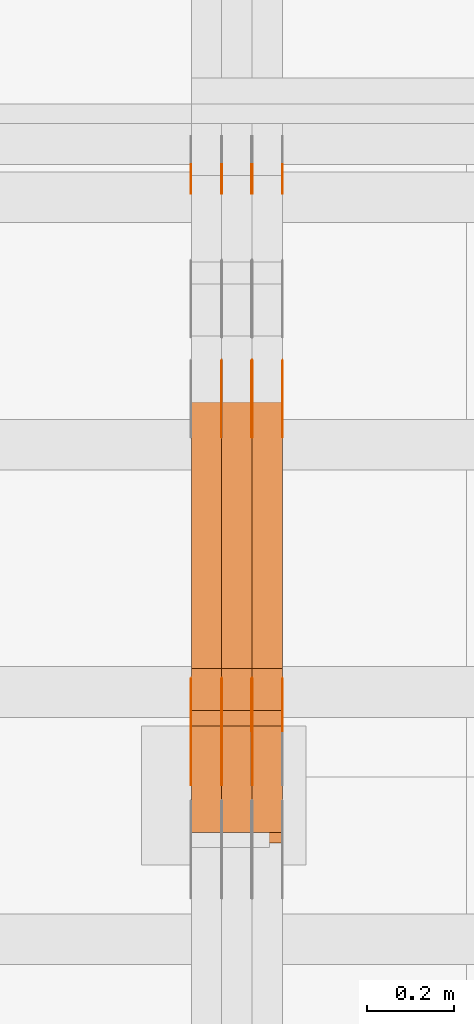
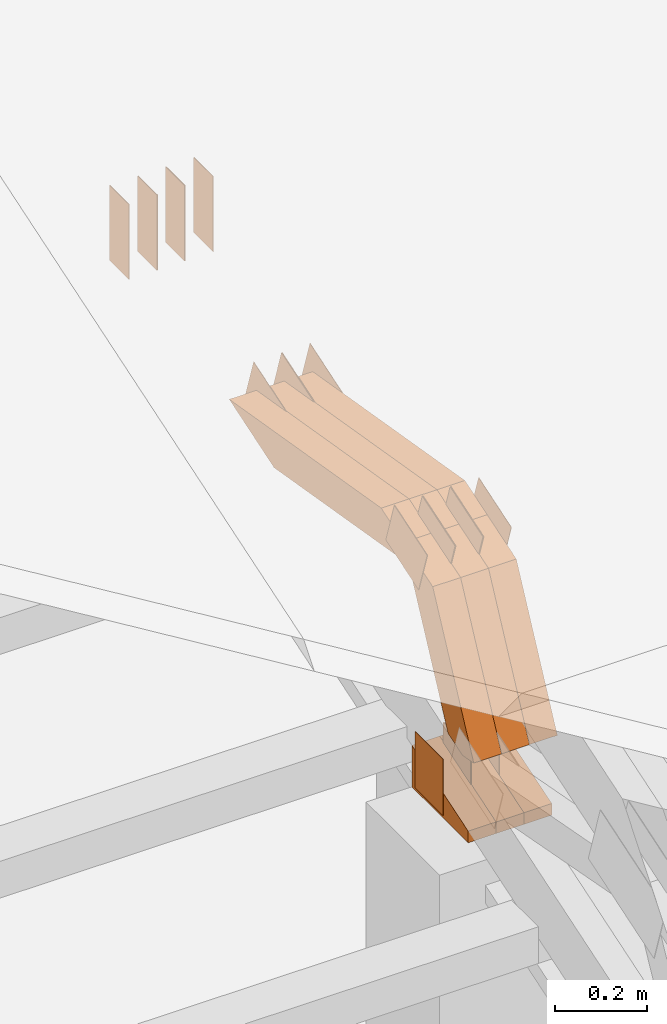
# One storey, part 80 of 385: 29 proxies.
"""IFC2X3 building model written with IfcOpenShell, lengths in millimetres."""

from ifc_helpers import new_model, entity, si_unit, converted_unit, derived_unit, direction, frame, frame_2d, origin, place, context, subcontext, project, spatial, polyline, rectangle, outline, extrude, source, transform, mapped, material, type_object, type_shapes, element, save


model = new_model("IFC2X3")

# Units and contexts
model_context = context("Model", 3, precision=0.01, world=origin(), true_north=direction((6.12303176911189e-17, 1.0)))
body_context = subcontext(model_context, "Body", "Model", "MODEL_VIEW")
ifc_project = project(units=[si_unit("LENGTHUNIT", "METRE", prefix="MILLI"), si_unit("AREAUNIT", "SQUARE_METRE"), si_unit("VOLUMEUNIT", "CUBIC_METRE"), converted_unit("PLANEANGLEUNIT", "DEGREE", entity("IfcRatioMeasure", 0.0174532925199433), si_unit("PLANEANGLEUNIT", "RADIAN"), dimensions=[0, 0, 0, 0, 0, 0, 0]), si_unit("MASSUNIT", "GRAM", prefix="KILO"), derived_unit("MASSDENSITYUNIT", [(si_unit("MASSUNIT", "GRAM", prefix="KILO"), 1), (si_unit("LENGTHUNIT", "METRE"), -3)]), si_unit("TIMEUNIT", "SECOND"), si_unit("FREQUENCYUNIT", "HERTZ"), si_unit("THERMODYNAMICTEMPERATUREUNIT", "DEGREE_CELSIUS"), derived_unit("THERMALTRANSMITTANCEUNIT", [(si_unit("MASSUNIT", "GRAM", prefix="KILO"), 1), (si_unit("THERMODYNAMICTEMPERATUREUNIT", "KELVIN"), -1), (si_unit("TIMEUNIT", "SECOND"), -3)]), derived_unit("VOLUMETRICFLOWRATEUNIT", [(si_unit("LENGTHUNIT", "METRE"), 3), (si_unit("TIMEUNIT", "SECOND"), -1)]), si_unit("ELECTRICCURRENTUNIT", "AMPERE"), si_unit("ELECTRICVOLTAGEUNIT", "VOLT"), si_unit("POWERUNIT", "WATT"), si_unit("FORCEUNIT", "NEWTON", prefix="KILO"), si_unit("ILLUMINANCEUNIT", "LUX"), si_unit("LUMINOUSFLUXUNIT", "LUMEN"), si_unit("LUMINOUSINTENSITYUNIT", "CANDELA"), derived_unit("USERDEFINED", [(si_unit("MASSUNIT", "GRAM", prefix="KILO"), -1), (si_unit("LENGTHUNIT", "METRE"), -2), (si_unit("TIMEUNIT", "SECOND"), 3), (si_unit("LUMINOUSFLUXUNIT", "LUMEN"), 1)]), derived_unit("LINEARVELOCITYUNIT", [(si_unit("LENGTHUNIT", "METRE"), 1), (si_unit("TIMEUNIT", "SECOND"), -1)]), si_unit("PRESSUREUNIT", "PASCAL"), derived_unit("USERDEFINED", [(si_unit("LENGTHUNIT", "METRE"), -2), (si_unit("MASSUNIT", "GRAM", prefix="KILO"), 1), (si_unit("TIMEUNIT", "SECOND"), -2)])], contexts=[model_context])

# Site, building, storey
site_placement = place(None, origin())
site = spatial("IfcSite", under=ifc_project, at=site_placement, CompositionType="ELEMENT")
building_placement = place(site_placement, origin())
building = spatial("IfcBuilding", under=site, at=building_placement, CompositionType="ELEMENT")
storey_placement = place(building_placement, origin())
storey = spatial("IfcBuildingStorey", under=building, at=storey_placement, Name="Default", CompositionType="ELEMENT", Elevation=0.0)

# Proxies
ifc_material_1 = material(Name="IfcSurfaceStyle #105844")
building_element_proxy_type_1 = type_object("IfcBuildingElementProxyType", PredefinedType="NOTDEFINED", material=ifc_material_1)
shared_shape_1 = source(origin(), body_context, "Body", "SweptSolid", [
    extrude(rectangle(XDim=200.0, YDim=84.0, at=frame_2d((0.0, -7.105427357601e-15), x_axis=(1.0, 0.0))), frame((100.0, 42.0, 0.0), z_axis=(0.0, 0.0, 1.0), x_axis=(-1.0, 0.0, 0.0)), (0.0, 0.0, 1.0), 1.3),
])
type_shapes(building_element_proxy_type_1, [shared_shape_1])
proxy_1_placement = place(building_placement, frame((6386.29999999999, 13702.0, 3651.4150390625), z_axis=(-1.0, 0.0, 0.0), x_axis=(0.0, 0.0, -1.0)))
element("IfcBuildingElementProxy", 1, at=proxy_1_placement, inside=storey, type_object=building_element_proxy_type_1, material=ifc_material_1, context=body_context, shape_type="MappedRepresentation", body=[
    mapped(shared_shape_1, transform((0.0, 0.0, 0.0), scale=1.0)),
])
ifc_material_2 = material(Name="IfcSurfaceStyle #105787")
building_element_proxy_type_2 = type_object("IfcBuildingElementProxyType", PredefinedType="NOTDEFINED", material=ifc_material_2)
shared_shape_2 = source(origin(), body_context, "Body", "SweptSolid", [
    extrude(rectangle(XDim=200.0, YDim=84.0, at=frame_2d((0.0, -7.105427357601e-15), x_axis=(1.0, 0.0))), frame((100.0, 42.0, 0.0), z_axis=(0.0, 0.0, 1.0), x_axis=(-1.0, 0.0, 0.0)), (0.0, 0.0, 1.0), 1.3),
])
type_shapes(building_element_proxy_type_2, [shared_shape_2])
proxy_2_placement = place(building_placement, frame((6315.0, 13702.0, 3651.4150390625), z_axis=(-1.0, 0.0, 0.0), x_axis=(0.0, 0.0, -1.0)))
element("IfcBuildingElementProxy", 2, at=proxy_2_placement, inside=storey, type_object=building_element_proxy_type_2, material=ifc_material_2, context=body_context, shape_type="MappedRepresentation", body=[
    mapped(shared_shape_2, transform((0.0, 0.0, 0.0), scale=1.0)),
])
ifc_material_3 = material(Name="IfcSurfaceStyle #105730")
building_element_proxy_type_3 = type_object("IfcBuildingElementProxyType", PredefinedType="NOTDEFINED", material=ifc_material_3)
shared_shape_3 = source(origin(), body_context, "Body", "SweptSolid", [
    extrude(rectangle(XDim=200.0, YDim=84.0, at=frame_2d((0.0, -7.105427357601e-15), x_axis=(1.0, 0.0))), frame((100.0, 42.0, 0.0), z_axis=(0.0, 0.0, 1.0), x_axis=(-1.0, 0.0, 0.0)), (0.0, 0.0, 1.0), 1.3),
])
type_shapes(building_element_proxy_type_3, [shared_shape_3])
proxy_3_placement = place(building_placement, frame((6316.29999999999, 13702.0, 3651.4150390625), z_axis=(-1.0, 0.0, 0.0), x_axis=(0.0, 0.0, -1.0)))
element("IfcBuildingElementProxy", 3, at=proxy_3_placement, inside=storey, type_object=building_element_proxy_type_3, material=ifc_material_3, context=body_context, shape_type="MappedRepresentation", body=[
    mapped(shared_shape_3, transform((0.0, 0.0, 0.0), scale=1.0)),
])
ifc_material_4 = material(Name="IfcSurfaceStyle #105673")
building_element_proxy_type_4 = type_object("IfcBuildingElementProxyType", PredefinedType="NOTDEFINED", material=ifc_material_4)
shared_shape_4 = source(origin(), body_context, "Body", "SweptSolid", [
    extrude(rectangle(XDim=200.0, YDim=84.0, at=frame_2d((0.0, -7.105427357601e-15), x_axis=(1.0, 0.0))), frame((100.0, 42.0, 0.0), z_axis=(0.0, 0.0, 1.0), x_axis=(-1.0, 0.0, 0.0)), (0.0, 0.0, 1.0), 1.29999999999998),
])
type_shapes(building_element_proxy_type_4, [shared_shape_4])
proxy_4_placement = place(building_placement, frame((6245.0, 13702.0, 3651.4150390625), z_axis=(-1.0, 0.0, 0.0), x_axis=(0.0, 0.0, -1.0)))
element("IfcBuildingElementProxy", 4, at=proxy_4_placement, inside=storey, type_object=building_element_proxy_type_4, material=ifc_material_4, context=body_context, shape_type="MappedRepresentation", body=[
    mapped(shared_shape_4, transform((0.0, 0.0, 0.0), scale=1.0)),
])
ifc_material_5 = material(Name="IfcSurfaceStyle #105616")
building_element_proxy_type_5 = type_object("IfcBuildingElementProxyType", PredefinedType="NOTDEFINED", material=ifc_material_5)
shared_shape_5 = source(origin(), body_context, "Body", "SweptSolid", [
    extrude(rectangle(XDim=200.0, YDim=84.0, at=frame_2d((0.0, -7.105427357601e-15), x_axis=(1.0, 0.0))), frame((100.0, 42.0, 0.0), z_axis=(0.0, 0.0, 1.0), x_axis=(-1.0, 0.0, 0.0)), (0.0, 0.0, 1.0), 1.29999999999998),
])
type_shapes(building_element_proxy_type_5, [shared_shape_5])
proxy_5_placement = place(building_placement, frame((6246.29999999999, 13702.0, 3651.4150390625), z_axis=(-1.0, 0.0, 0.0), x_axis=(0.0, 0.0, -1.0)))
element("IfcBuildingElementProxy", 5, at=proxy_5_placement, inside=storey, type_object=building_element_proxy_type_5, material=ifc_material_5, context=body_context, shape_type="MappedRepresentation", body=[
    mapped(shared_shape_5, transform((0.0, 0.0, 0.0), scale=1.0)),
])
ifc_material_6 = material(Name="IfcSurfaceStyle #105559")
building_element_proxy_type_6 = type_object("IfcBuildingElementProxyType", PredefinedType="NOTDEFINED", material=ifc_material_6)
shared_shape_6 = source(origin(), body_context, "Body", "SweptSolid", [
    extrude(rectangle(XDim=200.0, YDim=84.0, at=frame_2d((0.0, -7.105427357601e-15), x_axis=(1.0, 0.0))), frame((100.0, 42.0, 0.0), z_axis=(0.0, 0.0, 1.0), x_axis=(-1.0, 0.0, 0.0)), (0.0, 0.0, 1.0), 1.29999999999999),
])
type_shapes(building_element_proxy_type_6, [shared_shape_6])
proxy_6_placement = place(building_placement, frame((6175.0, 13702.0, 3651.4150390625), z_axis=(-1.0, 0.0, 0.0), x_axis=(0.0, 0.0, -1.0)))
element("IfcBuildingElementProxy", 6, at=proxy_6_placement, inside=storey, type_object=building_element_proxy_type_6, material=ifc_material_6, context=body_context, shape_type="MappedRepresentation", body=[
    mapped(shared_shape_6, transform((0.0, 0.0, 0.0), scale=1.0)),
])
ifc_material_7 = material(Name="IfcSurfaceStyle #105502")
building_element_proxy_type_7 = type_object("IfcBuildingElementProxyType", PredefinedType="NOTDEFINED", material=ifc_material_7)
shared_shape_7 = source(origin(), body_context, "Body", "SweptSolid", [
    extrude(outline(polyline([(-75.0003398116828, -59.9998507501386), (75.0003249421766, -59.9998507501386), (75.0003398116837, 59.9998507501387), (-75.0003249421775, 59.9998507501387), (-75.0003398116828, -59.9998507501386)])), frame((75.0003398116837, 60.0000773549637, 0.0), z_axis=(0.0, 0.0, 1.0), x_axis=(-1.0, 0.0, 0.0)), (0.0, 0.0, 1.0), 1.3),
])
type_shapes(building_element_proxy_type_7, [shared_shape_7])
proxy_7_placement = place(building_placement, frame((6386.29999999999, 13054.73046875, 3417.8388671875), z_axis=(-1.0, 0.0, 0.0), x_axis=(0.0, 0.951056516295124, 0.309016994375039)))
element("IfcBuildingElementProxy", 7, at=proxy_7_placement, inside=storey, type_object=building_element_proxy_type_7, material=ifc_material_7, context=body_context, shape_type="MappedRepresentation", body=[
    mapped(shared_shape_7, transform((0.0, 0.0, 0.0), scale=1.0)),
])
ifc_material_8 = material(Name="IfcSurfaceStyle #105445")
building_element_proxy_type_8 = type_object("IfcBuildingElementProxyType", PredefinedType="NOTDEFINED", material=ifc_material_8)
shared_shape_8 = source(origin(), body_context, "Body", "SweptSolid", [
    extrude(outline(polyline([(-75.0003398116828, -59.9998507501386), (75.0003249421766, -59.9998507501386), (75.0003398116837, 59.9998507501387), (-75.0003249421775, 59.9998507501387), (-75.0003398116828, -59.9998507501386)])), frame((75.0003398116837, 60.0000773549637, 0.0), z_axis=(0.0, 0.0, 1.0), x_axis=(-1.0, 0.0, 0.0)), (0.0, 0.0, 1.0), 1.3),
])
type_shapes(building_element_proxy_type_8, [shared_shape_8])
proxy_8_placement = place(building_placement, frame((6315.0, 13054.73046875, 3417.8388671875), z_axis=(-1.0, 0.0, 0.0), x_axis=(0.0, 0.951056516295124, 0.309016994375039)))
element("IfcBuildingElementProxy", 8, at=proxy_8_placement, inside=storey, type_object=building_element_proxy_type_8, material=ifc_material_8, context=body_context, shape_type="MappedRepresentation", body=[
    mapped(shared_shape_8, transform((0.0, 0.0, 0.0), scale=1.0)),
])
ifc_material_9 = material(Name="IfcSurfaceStyle #105388")
building_element_proxy_type_9 = type_object("IfcBuildingElementProxyType", PredefinedType="NOTDEFINED", material=ifc_material_9)
shared_shape_9 = source(origin(), body_context, "Body", "SweptSolid", [
    extrude(outline(polyline([(-75.0003398116828, -59.9998507501386), (75.0003249421766, -59.9998507501386), (75.0003398116837, 59.9998507501387), (-75.0003249421775, 59.9998507501387), (-75.0003398116828, -59.9998507501386)])), frame((75.0003398116837, 60.0000773549637, 0.0), z_axis=(0.0, 0.0, 1.0), x_axis=(-1.0, 0.0, 0.0)), (0.0, 0.0, 1.0), 1.3),
])
type_shapes(building_element_proxy_type_9, [shared_shape_9])
proxy_9_placement = place(building_placement, frame((6316.29999999999, 13054.73046875, 3417.8388671875), z_axis=(-1.0, 0.0, 0.0), x_axis=(0.0, 0.951056516295124, 0.309016994375039)))
element("IfcBuildingElementProxy", 9, at=proxy_9_placement, inside=storey, type_object=building_element_proxy_type_9, material=ifc_material_9, context=body_context, shape_type="MappedRepresentation", body=[
    mapped(shared_shape_9, transform((0.0, 0.0, 0.0), scale=1.0)),
])
ifc_material_10 = material(Name="IfcSurfaceStyle #105331")
building_element_proxy_type_10 = type_object("IfcBuildingElementProxyType", PredefinedType="NOTDEFINED", material=ifc_material_10)
shared_shape_10 = source(origin(), body_context, "Body", "SweptSolid", [
    extrude(outline(polyline([(-75.0003398116828, -59.9998507501386), (75.0003249421766, -59.9998507501386), (75.0003398116837, 59.9998507501387), (-75.0003249421775, 59.9998507501387), (-75.0003398116828, -59.9998507501386)])), frame((75.0003398116837, 60.0000773549637, 0.0), z_axis=(0.0, 0.0, 1.0), x_axis=(-1.0, 0.0, 0.0)), (0.0, 0.0, 1.0), 1.29999999999999),
])
type_shapes(building_element_proxy_type_10, [shared_shape_10])
proxy_10_placement = place(building_placement, frame((6245.0, 13054.73046875, 3417.8388671875), z_axis=(-1.0, 0.0, 0.0), x_axis=(0.0, 0.951056516295124, 0.309016994375039)))
element("IfcBuildingElementProxy", 10, at=proxy_10_placement, inside=storey, type_object=building_element_proxy_type_10, material=ifc_material_10, context=body_context, shape_type="MappedRepresentation", body=[
    mapped(shared_shape_10, transform((0.0, 0.0, 0.0), scale=1.0)),
])
ifc_material_11 = material(Name="IfcSurfaceStyle #103336")
building_element_proxy_type_11 = type_object("IfcBuildingElementProxyType", PredefinedType="NOTDEFINED", material=ifc_material_11)
shared_shape_11 = source(origin(), body_context, "Body", "SweptSolid", [
    extrude(rectangle(XDim=150.0, YDim=119.999999999985, at=frame_2d((-7.105427357601e-15, 0.0), x_axis=(1.0, 0.0))), frame((75.0, 60.0, 0.0), z_axis=(0.0, 0.0, 1.0), x_axis=(-1.0, 0.0, 0.0)), (0.0, 0.0, 1.0), 1.3),
])
type_shapes(building_element_proxy_type_11, [shared_shape_11])
proxy_11_placement = place(building_placement, frame((6316.29999999999, 12372.95703125, 3007.04687500001), z_axis=(-1.0, 0.0, 0.0), x_axis=(0.0, 0.0, -1.0)))
element("IfcBuildingElementProxy", 11, at=proxy_11_placement, inside=storey, type_object=building_element_proxy_type_11, material=ifc_material_11, context=body_context, shape_type="MappedRepresentation", body=[
    mapped(shared_shape_11, transform((0.0, 0.0, 0.0), scale=1.0)),
])
ifc_material_12 = material(Name="IfcSurfaceStyle #103279")
building_element_proxy_type_12 = type_object("IfcBuildingElementProxyType", PredefinedType="NOTDEFINED", material=ifc_material_12)
shared_shape_12 = source(origin(), body_context, "Body", "SweptSolid", [
    extrude(rectangle(XDim=150.0, YDim=119.999999999985, at=frame_2d((-7.105427357601e-15, 0.0), x_axis=(1.0, 0.0))), frame((75.0, 60.0, 0.0), z_axis=(0.0, 0.0, 1.0), x_axis=(-1.0, 0.0, 0.0)), (0.0, 0.0, 1.0), 1.29999999999999),
])
type_shapes(building_element_proxy_type_12, [shared_shape_12])
proxy_12_placement = place(building_placement, frame((6245.0, 12372.95703125, 3007.04687500001), z_axis=(-1.0, 0.0, 0.0), x_axis=(0.0, 0.0, -1.0)))
element("IfcBuildingElementProxy", 12, at=proxy_12_placement, inside=storey, type_object=building_element_proxy_type_12, material=ifc_material_12, context=body_context, shape_type="MappedRepresentation", body=[
    mapped(shared_shape_12, transform((0.0, 0.0, 0.0), scale=1.0)),
])
ifc_material_13 = material(Name="IfcSurfaceStyle #103222")
building_element_proxy_type_13 = type_object("IfcBuildingElementProxyType", PredefinedType="NOTDEFINED", material=ifc_material_13)
shared_shape_13 = source(origin(), body_context, "Body", "SweptSolid", [
    extrude(rectangle(XDim=150.0, YDim=119.999999999985, at=frame_2d((-7.105427357601e-15, 0.0), x_axis=(1.0, 0.0))), frame((75.0, 60.0, 0.0), z_axis=(0.0, 0.0, 1.0), x_axis=(-1.0, 0.0, 0.0)), (0.0, 0.0, 1.0), 1.29999999999999),
])
type_shapes(building_element_proxy_type_13, [shared_shape_13])
proxy_13_placement = place(building_placement, frame((6246.29999999999, 12372.95703125, 3007.04687500001), z_axis=(-1.0, 0.0, 0.0), x_axis=(0.0, 0.0, -1.0)))
element("IfcBuildingElementProxy", 13, at=proxy_13_placement, inside=storey, type_object=building_element_proxy_type_13, material=ifc_material_13, context=body_context, shape_type="MappedRepresentation", body=[
    mapped(shared_shape_13, transform((0.0, 0.0, 0.0), scale=1.0)),
])
ifc_material_14 = material(Name="IfcSurfaceStyle #103165")
building_element_proxy_type_14 = type_object("IfcBuildingElementProxyType", PredefinedType="NOTDEFINED", material=ifc_material_14)
shared_shape_14 = source(origin(), body_context, "Body", "SweptSolid", [
    extrude(rectangle(XDim=150.0, YDim=119.999999999985, at=frame_2d((-7.105427357601e-15, 0.0), x_axis=(1.0, 0.0))), frame((75.0, 60.0, 0.0), z_axis=(0.0, 0.0, 1.0), x_axis=(-1.0, 0.0, 0.0)), (0.0, 0.0, 1.0), 1.29999999999999),
])
type_shapes(building_element_proxy_type_14, [shared_shape_14])
proxy_14_placement = place(building_placement, frame((6175.0, 12372.95703125, 3007.04687500001), z_axis=(-1.0, 0.0, 0.0), x_axis=(0.0, 0.0, -1.0)))
element("IfcBuildingElementProxy", 14, at=proxy_14_placement, inside=storey, type_object=building_element_proxy_type_14, material=ifc_material_14, context=body_context, shape_type="MappedRepresentation", body=[
    mapped(shared_shape_14, transform((0.0, 0.0, 0.0), scale=1.0)),
])
ifc_material_15 = material(Name="IfcSurfaceStyle #96268")
building_element_proxy_type_15 = type_object("IfcBuildingElementProxyType", PredefinedType="NOTDEFINED", material=ifc_material_15)
shared_shape_15 = source(origin(), body_context, "Body", "SweptSolid", [
    extrude(outline(polyline([(-74.9998754286244, -60.0000016373506), (74.9998605591063, -60.0000016373506), (74.9998754286244, 60.0000016373506), (-74.9998605591063, 60.0000016373506), (-74.9998754286244, -60.0000016373506)])), frame((74.9998754286244, 60.0000016373506, 0.0), z_axis=(0.0, 0.0, 1.0), x_axis=(-1.0, 0.0, 0.0)), (0.0, 0.0, 1.0), 1.3),
])
type_shapes(building_element_proxy_type_15, [shared_shape_15])
proxy_15_placement = place(building_placement, frame((6386.29999999999, 12321.1620861463, 3506.17707344366), z_axis=(-1.0, 0.0, 0.0), x_axis=(0.0, 0.951056516295154, 0.309016994374948)))
element("IfcBuildingElementProxy", 15, at=proxy_15_placement, inside=storey, type_object=building_element_proxy_type_15, material=ifc_material_15, context=body_context, shape_type="MappedRepresentation", body=[
    mapped(shared_shape_15, transform((0.0, 0.0, 0.0), scale=1.0)),
])
ifc_material_16 = material(Name="IfcSurfaceStyle #96211")
building_element_proxy_type_16 = type_object("IfcBuildingElementProxyType", PredefinedType="NOTDEFINED", material=ifc_material_16)
shared_shape_16 = source(origin(), body_context, "Body", "SweptSolid", [
    extrude(outline(polyline([(-74.9998754286244, -60.0000016373506), (74.9998605591063, -60.0000016373506), (74.9998754286244, 60.0000016373506), (-74.9998605591063, 60.0000016373506), (-74.9998754286244, -60.0000016373506)])), frame((74.9998754286244, 60.0000016373506, 0.0), z_axis=(0.0, 0.0, 1.0), x_axis=(-1.0, 0.0, 0.0)), (0.0, 0.0, 1.0), 1.3),
])
type_shapes(building_element_proxy_type_16, [shared_shape_16])
proxy_16_placement = place(building_placement, frame((6315.0, 12321.1620861463, 3506.17707344366), z_axis=(-1.0, 0.0, 0.0), x_axis=(0.0, 0.951056516295154, 0.309016994374948)))
element("IfcBuildingElementProxy", 16, at=proxy_16_placement, inside=storey, type_object=building_element_proxy_type_16, material=ifc_material_16, context=body_context, shape_type="MappedRepresentation", body=[
    mapped(shared_shape_16, transform((0.0, 0.0, 0.0), scale=1.0)),
])
ifc_material_17 = material(Name="IfcSurfaceStyle #96154")
building_element_proxy_type_17 = type_object("IfcBuildingElementProxyType", PredefinedType="NOTDEFINED", material=ifc_material_17)
shared_shape_17 = source(origin(), body_context, "Body", "SweptSolid", [
    extrude(outline(polyline([(-74.9998754286244, -60.0000016373506), (74.9998605591063, -60.0000016373506), (74.9998754286244, 60.0000016373506), (-74.9998605591063, 60.0000016373506), (-74.9998754286244, -60.0000016373506)])), frame((74.9998754286244, 60.0000016373506, 0.0), z_axis=(0.0, 0.0, 1.0), x_axis=(-1.0, 0.0, 0.0)), (0.0, 0.0, 1.0), 1.3),
])
type_shapes(building_element_proxy_type_17, [shared_shape_17])
proxy_17_placement = place(building_placement, frame((6316.29999999999, 12321.1620861463, 3506.17707344366), z_axis=(-1.0, 0.0, 0.0), x_axis=(0.0, 0.951056516295154, 0.309016994374948)))
element("IfcBuildingElementProxy", 17, at=proxy_17_placement, inside=storey, type_object=building_element_proxy_type_17, material=ifc_material_17, context=body_context, shape_type="MappedRepresentation", body=[
    mapped(shared_shape_17, transform((0.0, 0.0, 0.0), scale=1.0)),
])
ifc_material_18 = material(Name="IfcSurfaceStyle #96097")
building_element_proxy_type_18 = type_object("IfcBuildingElementProxyType", PredefinedType="NOTDEFINED", material=ifc_material_18)
shared_shape_18 = source(origin(), body_context, "Body", "SweptSolid", [
    extrude(outline(polyline([(-74.9998754286244, -60.0000016373506), (74.9998605591063, -60.0000016373506), (74.9998754286244, 60.0000016373506), (-74.9998605591063, 60.0000016373506), (-74.9998754286244, -60.0000016373506)])), frame((74.9998754286244, 60.0000016373506, 0.0), z_axis=(0.0, 0.0, 1.0), x_axis=(-1.0, 0.0, 0.0)), (0.0, 0.0, 1.0), 1.29999999999999),
])
type_shapes(building_element_proxy_type_18, [shared_shape_18])
proxy_18_placement = place(building_placement, frame((6245.0, 12321.1620861463, 3506.17707344366), z_axis=(-1.0, 0.0, 0.0), x_axis=(0.0, 0.951056516295154, 0.309016994374948)))
element("IfcBuildingElementProxy", 18, at=proxy_18_placement, inside=storey, type_object=building_element_proxy_type_18, material=ifc_material_18, context=body_context, shape_type="MappedRepresentation", body=[
    mapped(shared_shape_18, transform((0.0, 0.0, 0.0), scale=1.0)),
])
ifc_material_19 = material(Name="IfcSurfaceStyle #96040")
building_element_proxy_type_19 = type_object("IfcBuildingElementProxyType", PredefinedType="NOTDEFINED", material=ifc_material_19)
shared_shape_19 = source(origin(), body_context, "Body", "SweptSolid", [
    extrude(outline(polyline([(-74.9998754286244, -60.0000016373506), (74.9998605591063, -60.0000016373506), (74.9998754286244, 60.0000016373506), (-74.9998605591063, 60.0000016373506), (-74.9998754286244, -60.0000016373506)])), frame((74.9998754286244, 60.0000016373506, 0.0), z_axis=(0.0, 0.0, 1.0), x_axis=(-1.0, 0.0, 0.0)), (0.0, 0.0, 1.0), 1.29999999999999),
])
type_shapes(building_element_proxy_type_19, [shared_shape_19])
proxy_19_placement = place(building_placement, frame((6246.29999999999, 12321.1620861463, 3506.17707344366), z_axis=(-1.0, 0.0, 0.0), x_axis=(0.0, 0.951056516295154, 0.309016994374948)))
element("IfcBuildingElementProxy", 19, at=proxy_19_placement, inside=storey, type_object=building_element_proxy_type_19, material=ifc_material_19, context=body_context, shape_type="MappedRepresentation", body=[
    mapped(shared_shape_19, transform((0.0, 0.0, 0.0), scale=1.0)),
])
ifc_material_20 = material(Name="IfcSurfaceStyle #95983")
building_element_proxy_type_20 = type_object("IfcBuildingElementProxyType", PredefinedType="NOTDEFINED", material=ifc_material_20)
shared_shape_20 = source(origin(), body_context, "Body", "SweptSolid", [
    extrude(outline(polyline([(-74.9998754286244, -60.0000016373506), (74.9998605591063, -60.0000016373506), (74.9998754286244, 60.0000016373506), (-74.9998605591063, 60.0000016373506), (-74.9998754286244, -60.0000016373506)])), frame((74.9998754286244, 60.0000016373506, 0.0), z_axis=(0.0, 0.0, 1.0), x_axis=(-1.0, 0.0, 0.0)), (0.0, 0.0, 1.0), 1.29999999999999),
])
type_shapes(building_element_proxy_type_20, [shared_shape_20])
proxy_20_placement = place(building_placement, frame((6175.0, 12321.1620861463, 3506.17707344366), z_axis=(-1.0, 0.0, 0.0), x_axis=(0.0, 0.951056516295154, 0.309016994374948)))
element("IfcBuildingElementProxy", 20, at=proxy_20_placement, inside=storey, type_object=building_element_proxy_type_20, material=ifc_material_20, context=body_context, shape_type="MappedRepresentation", body=[
    mapped(shared_shape_20, transform((0.0, 0.0, 0.0), scale=1.0)),
])
ifc_material_21 = material(Name="IfcSurfaceStyle #87808")
building_element_proxy_type_21 = type_object("IfcBuildingElementProxyType", Name="T1-E1 87806", PredefinedType="NOTDEFINED", material=ifc_material_21)
shared_shape_21 = source(origin(), body_context, "Body", "SweptSolid", [
    extrude(outline(polyline([(-75.1378173828004, -122.500000000005), (35.3350830078246, -122.500000000005), (35.3350830078004, 122.500000000005), (4.46765136717545, 122.500000000005), (-75.1378173828004, -122.500000000005)])), frame((35.3350830078246, 122.500000104877, 0.0), z_axis=(0.0, 0.0, 1.0), x_axis=(-1.0, 0.0, 0.0)), (0.0, 0.0, 1.0), 70.0),
])
type_shapes(building_element_proxy_type_21, [shared_shape_21])
proxy_21_placement = place(building_placement, frame((6385.0, 12145.0, 2849.54565429685), z_axis=(-1.0, 0.0, 0.0), x_axis=(0.0, 0.0, 1.0)))
element("IfcBuildingElementProxy", 21, at=proxy_21_placement, inside=storey, type_object=building_element_proxy_type_21, material=ifc_material_21, Name="T1-E1", context=body_context, shape_type="MappedRepresentation", body=[
    mapped(shared_shape_21, transform((0.0, 0.0, 0.0), scale=1.0)),
])
ifc_material_22 = material(Name="IfcSurfaceStyle #87751")
building_element_proxy_type_22 = type_object("IfcBuildingElementProxyType", Name="T1-E1 87749", PredefinedType="NOTDEFINED", material=ifc_material_22)
shared_shape_22 = source(origin(), body_context, "Body", "SweptSolid", [
    extrude(outline(polyline([(-75.1378173828004, -122.500000000005), (35.3350830078246, -122.500000000005), (35.3350830078004, 122.500000000005), (4.46765136717545, 122.500000000005), (-75.1378173828004, -122.500000000005)])), frame((35.3350830078246, 122.500000104877, 0.0), z_axis=(0.0, 0.0, 1.0), x_axis=(-1.0, 0.0, 0.0)), (0.0, 0.0, 1.0), 70.0),
])
type_shapes(building_element_proxy_type_22, [shared_shape_22])
proxy_22_placement = place(building_placement, frame((6315.0, 12145.0, 2849.54565429685), z_axis=(-1.0, 0.0, 0.0), x_axis=(0.0, 0.0, 1.0)))
element("IfcBuildingElementProxy", 22, at=proxy_22_placement, inside=storey, type_object=building_element_proxy_type_22, material=ifc_material_22, Name="T1-E1", context=body_context, shape_type="MappedRepresentation", body=[
    mapped(shared_shape_22, transform((0.0, 0.0, 0.0), scale=1.0)),
])
ifc_material_23 = material(Name="IfcSurfaceStyle #87694")
building_element_proxy_type_23 = type_object("IfcBuildingElementProxyType", Name="T1-E1 87692", PredefinedType="NOTDEFINED", material=ifc_material_23)
shared_shape_23 = source(origin(), body_context, "Body", "SweptSolid", [
    extrude(outline(polyline([(-75.1378173828004, -122.500000000005), (35.3350830078246, -122.500000000005), (35.3350830078004, 122.500000000005), (4.46765136717545, 122.500000000005), (-75.1378173828004, -122.500000000005)])), frame((35.3350830078246, 122.500000104877, 0.0), z_axis=(0.0, 0.0, 1.0), x_axis=(-1.0, 0.0, 0.0)), (0.0, 0.0, 1.0), 70.0),
])
type_shapes(building_element_proxy_type_23, [shared_shape_23])
proxy_23_placement = place(building_placement, frame((6245.0, 12145.0, 2849.54565429685), z_axis=(-1.0, 0.0, 0.0), x_axis=(0.0, 0.0, 1.0)))
element("IfcBuildingElementProxy", 23, at=proxy_23_placement, inside=storey, type_object=building_element_proxy_type_23, material=ifc_material_23, Name="T1-E1", context=body_context, shape_type="MappedRepresentation", body=[
    mapped(shared_shape_23, transform((0.0, 0.0, 0.0), scale=1.0)),
])
ifc_material_24 = material(Name="IfcSurfaceStyle #86080")
building_element_proxy_type_24 = type_object("IfcBuildingElementProxyType", Name="T1-W7 86078", PredefinedType="NOTDEFINED", material=ifc_material_24)
shared_shape_24 = source(origin(), body_context, "Body", "SweptSolid", [
    extrude(outline(polyline([(-296.174043820986, -47.5000676566704), (297.841254477443, -47.5000676566704), (283.518570346415, -7.10254316533821e-06), (192.674144473719, 47.500071207942), (-477.859925476591, 47.500071207942), (-296.174043820986, -47.5000676566704)])), frame((297.841254477443, 47.5000816097442, 0.0), z_axis=(0.0, 0.0, 1.0), x_axis=(-1.0, 0.0, 0.0)), (0.0, 0.0, 1.0), 70.0),
])
type_shapes(building_element_proxy_type_24, [shared_shape_24])
proxy_24_placement = place(building_placement, frame((6385.0, 12419.2991208897, 3526.2136755972), z_axis=(-1.0, 0.0, 0.0), x_axis=(0.0, 0.985983815111804, -0.166840991178939)))
element("IfcBuildingElementProxy", 24, at=proxy_24_placement, inside=storey, type_object=building_element_proxy_type_24, material=ifc_material_24, Name="T1-W7", context=body_context, shape_type="MappedRepresentation", body=[
    mapped(shared_shape_24, transform((0.0, 0.0, 0.0), scale=1.0)),
])
ifc_material_25 = material(Name="IfcSurfaceStyle #86014")
building_element_proxy_type_25 = type_object("IfcBuildingElementProxyType", Name="T1-W7 86012", PredefinedType="NOTDEFINED", material=ifc_material_25)
shared_shape_25 = source(origin(), body_context, "Body", "SweptSolid", [
    extrude(outline(polyline([(-296.174043820986, -47.5000676566704), (297.841254477443, -47.5000676566704), (283.518570346415, -7.10254316533821e-06), (192.674144473719, 47.500071207942), (-477.859925476591, 47.500071207942), (-296.174043820986, -47.5000676566704)])), frame((297.841254477443, 47.5000816097442, 0.0), z_axis=(0.0, 0.0, 1.0), x_axis=(-1.0, 0.0, 0.0)), (0.0, 0.0, 1.0), 70.0),
])
type_shapes(building_element_proxy_type_25, [shared_shape_25])
proxy_25_placement = place(building_placement, frame((6315.0, 12419.2991208897, 3526.2136755972), z_axis=(-1.0, 0.0, 0.0), x_axis=(0.0, 0.985983815111804, -0.166840991178939)))
element("IfcBuildingElementProxy", 25, at=proxy_25_placement, inside=storey, type_object=building_element_proxy_type_25, material=ifc_material_25, Name="T1-W7", context=body_context, shape_type="MappedRepresentation", body=[
    mapped(shared_shape_25, transform((0.0, 0.0, 0.0), scale=1.0)),
])
ifc_material_26 = material(Name="IfcSurfaceStyle #85948")
building_element_proxy_type_26 = type_object("IfcBuildingElementProxyType", Name="T1-W7 85946", PredefinedType="NOTDEFINED", material=ifc_material_26)
shared_shape_26 = source(origin(), body_context, "Body", "SweptSolid", [
    extrude(outline(polyline([(-296.174043820986, -47.5000676566704), (297.841254477443, -47.5000676566704), (283.518570346415, -7.10254316533821e-06), (192.674144473719, 47.500071207942), (-477.859925476591, 47.500071207942), (-296.174043820986, -47.5000676566704)])), frame((297.841254477443, 47.5000816097442, 0.0), z_axis=(0.0, 0.0, 1.0), x_axis=(-1.0, 0.0, 0.0)), (0.0, 0.0, 1.0), 70.0),
])
type_shapes(building_element_proxy_type_26, [shared_shape_26])
proxy_26_placement = place(building_placement, frame((6245.0, 12419.2991208897, 3526.2136755972), z_axis=(-1.0, 0.0, 0.0), x_axis=(0.0, 0.985983815111804, -0.166840991178939)))
element("IfcBuildingElementProxy", 26, at=proxy_26_placement, inside=storey, type_object=building_element_proxy_type_26, material=ifc_material_26, Name="T1-W7", context=body_context, shape_type="MappedRepresentation", body=[
    mapped(shared_shape_26, transform((0.0, 0.0, 0.0), scale=1.0)),
])
ifc_material_27 = material(Name="IfcSurfaceStyle #85684")
building_element_proxy_type_27 = type_object("IfcBuildingElementProxyType", Name="T1-W36 85682", PredefinedType="NOTDEFINED", material=ifc_material_27)
shared_shape_27 = source(origin(), body_context, "Body", "SweptSolid", [
    extrude(outline(polyline([(-300.714670922549, -47.4998881108849), (134.031527004269, -47.499888110885), (180.52054953879, -0.000136170977331764), (193.89900152221, 47.500563476126), (-207.736407142719, 47.4993489166213), (-300.714670922549, -47.4998881108849)])), frame((193.899145164686, 47.5001861375837, 0.0), z_axis=(0.0, 0.0, 1.0), x_axis=(-1.0, 3.02403492980632e-06, 0.0)), (0.0, 0.0, 1.0), 70.0),
])
type_shapes(building_element_proxy_type_27, [shared_shape_27])
proxy_27_placement = place(building_placement, frame((6385.0, 12120.5935627532, 3076.1128858536), z_axis=(-1.0, 0.0, 0.0), x_axis=(0.0, 0.444384650266842, 0.895836080210669)))
element("IfcBuildingElementProxy", 27, at=proxy_27_placement, inside=storey, type_object=building_element_proxy_type_27, material=ifc_material_27, Name="T1-W36", context=body_context, shape_type="MappedRepresentation", body=[
    mapped(shared_shape_27, transform((0.0, 0.0, 0.0), scale=1.0)),
])
ifc_material_28 = material(Name="IfcSurfaceStyle #85618")
building_element_proxy_type_28 = type_object("IfcBuildingElementProxyType", Name="T1-W36 85616", PredefinedType="NOTDEFINED", material=ifc_material_28)
shared_shape_28 = source(origin(), body_context, "Body", "SweptSolid", [
    extrude(outline(polyline([(-300.714670922549, -47.4998881108849), (134.031527004269, -47.499888110885), (180.52054953879, -0.000136170977331764), (193.89900152221, 47.500563476126), (-207.736407142719, 47.4993489166213), (-300.714670922549, -47.4998881108849)])), frame((193.899145164686, 47.5001861375837, 0.0), z_axis=(0.0, 0.0, 1.0), x_axis=(-1.0, 3.02403492980632e-06, 0.0)), (0.0, 0.0, 1.0), 70.0),
])
type_shapes(building_element_proxy_type_28, [shared_shape_28])
proxy_28_placement = place(building_placement, frame((6315.0, 12120.5935627532, 3076.1128858536), z_axis=(-1.0, 0.0, 0.0), x_axis=(0.0, 0.444384650266842, 0.895836080210669)))
element("IfcBuildingElementProxy", 28, at=proxy_28_placement, inside=storey, type_object=building_element_proxy_type_28, material=ifc_material_28, Name="T1-W36", context=body_context, shape_type="MappedRepresentation", body=[
    mapped(shared_shape_28, transform((0.0, 0.0, 0.0), scale=1.0)),
])
ifc_material_29 = material(Name="IfcSurfaceStyle #85552")
building_element_proxy_type_29 = type_object("IfcBuildingElementProxyType", Name="T1-W36 85550", PredefinedType="NOTDEFINED", material=ifc_material_29)
shared_shape_29 = source(origin(), body_context, "Body", "SweptSolid", [
    extrude(outline(polyline([(-300.714670922549, -47.4998881108849), (134.031527004269, -47.499888110885), (180.52054953879, -0.000136170977331764), (193.89900152221, 47.500563476126), (-207.736407142719, 47.4993489166213), (-300.714670922549, -47.4998881108849)])), frame((193.899145164686, 47.5001861375837, 0.0), z_axis=(0.0, 0.0, 1.0), x_axis=(-1.0, 3.02403492980632e-06, 0.0)), (0.0, 0.0, 1.0), 70.0),
])
type_shapes(building_element_proxy_type_29, [shared_shape_29])
proxy_29_placement = place(building_placement, frame((6245.0, 12120.5935627532, 3076.1128858536), z_axis=(-1.0, 0.0, 0.0), x_axis=(0.0, 0.444384650266842, 0.895836080210669)))
element("IfcBuildingElementProxy", 29, at=proxy_29_placement, inside=storey, type_object=building_element_proxy_type_29, material=ifc_material_29, Name="T1-W36", context=body_context, shape_type="MappedRepresentation", body=[
    mapped(shared_shape_29, transform((0.0, 0.0, 0.0), scale=1.0)),
])

save(model, "model.ifc")
